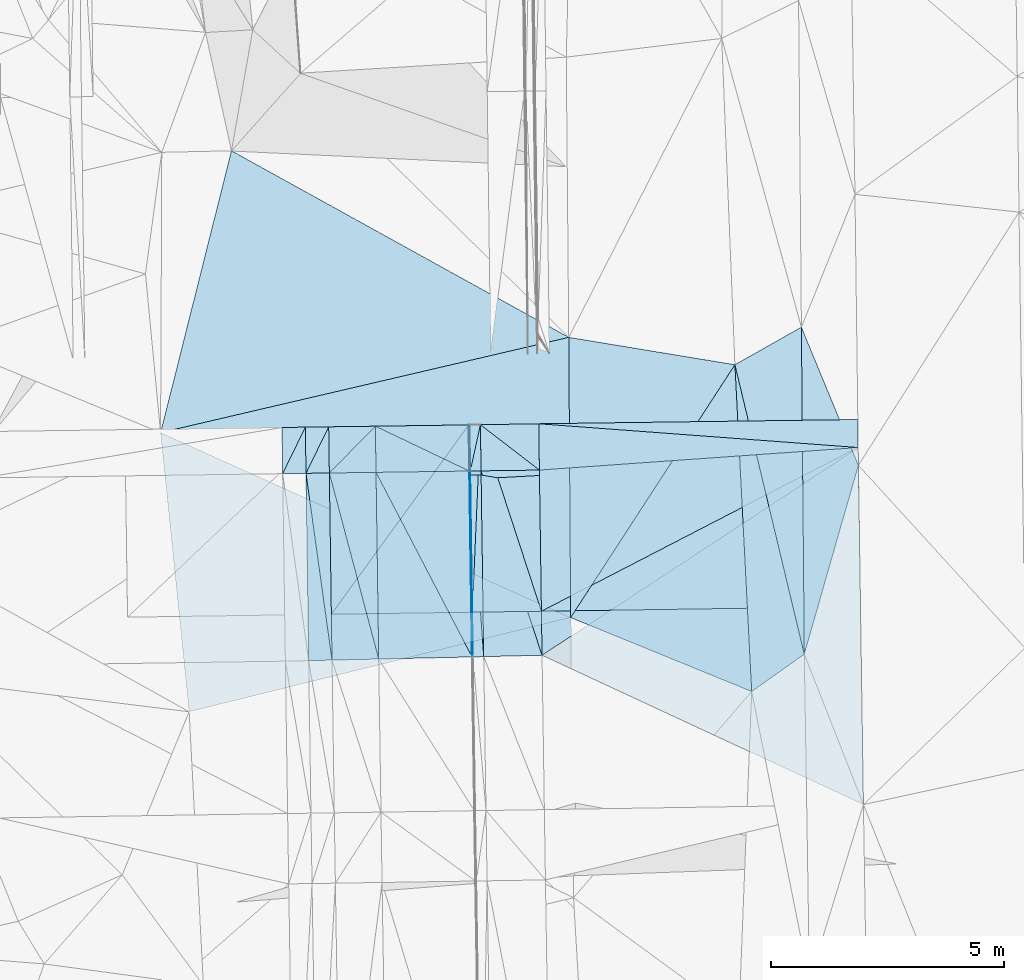
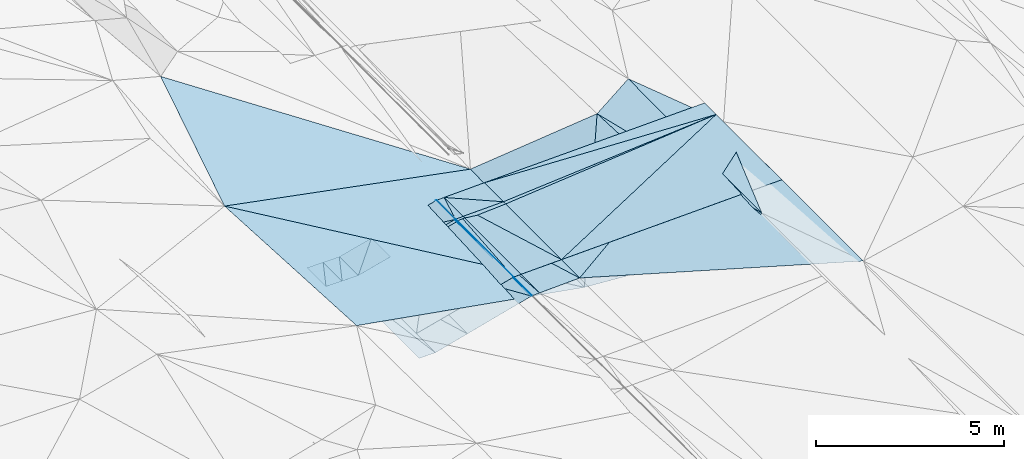
# One storey, part 8 of 275: 46 plates.
"""IFC2X3 building model written with IfcOpenShell, lengths in millimetres."""

from ifc_helpers import new_model, si_unit, frame, origin_with_axes, place, context, subcontext, project, spatial, polyline, outline, extrude, material, type_object, element, save


model = new_model("IFC2X3")

# Units and contexts
model_context = context("Model", 3, precision=1e-05, world=origin_with_axes())
body_context = subcontext(model_context, "Body", "Model", "MODEL_VIEW")
ifc_project = project(units=[si_unit("LENGTHUNIT", "METRE", prefix="MILLI"), si_unit("AREAUNIT", "SQUARE_METRE"), si_unit("VOLUMEUNIT", "CUBIC_METRE"), si_unit("MASSUNIT", "GRAM", prefix="KILO"), si_unit("TIMEUNIT", "SECOND"), si_unit("PLANEANGLEUNIT", "RADIAN"), si_unit("SOLIDANGLEUNIT", "STERADIAN"), si_unit("THERMODYNAMICTEMPERATUREUNIT", "DEGREE_CELSIUS"), si_unit("LUMINOUSINTENSITYUNIT", "LUMEN")], contexts=[model_context])

# Site, building, storey
site_placement = place(None, origin_with_axes())
site = spatial("IfcSite", under=ifc_project, at=site_placement, CompositionType="ELEMENT")
building_placement = place(site_placement, origin_with_axes())
building = spatial("IfcBuilding", under=site, at=building_placement, Name="Undefined", CompositionType="ELEMENT")
storey_placement = place(building_placement, origin_with_axes())
storey = spatial("IfcBuildingStorey", under=building, at=storey_placement, Name="Undefined", CompositionType="ELEMENT", Elevation=0.0)

# Plates
ifc_material = material()
plate_type_1 = type_object("IfcPlateType", PredefinedType="NOTDEFINED")
plate_1_placement = place(storey_placement, frame((-93513.8792285141, -4218.71586705667, 40889.5652154385), z_axis=(0.020856798243024, 0.0210911512834636, -0.999559981844305), x_axis=(-0.999682181351949, -0.013720854073878, -0.0211488640567715)))
element("IfcPlate", 1, at=plate_1_placement, inside=storey, type_object=plate_type_1, material=ifc_material, Name="00_PR", context=body_context, shape_type="SweptSolid", body=[
    extrude(outline(polyline([(0.0, 0.0), (1250.27990722656, -3.6216079024598e-09), (1250.25964355469, 4012.908203125), (0.0, 0.0)])), frame((-8.85201319254618e-08, 2.18876761149539e-07, -0.5000001331573), z_axis=(0.0, 0.0, 1.0), x_axis=(1.0, 0.0, 0.0)), (0.0, 0.0, 1.0), 1.0),
])
plate_2_placement = place(storey_placement, frame((-94806.8270014594, -1212.06963349907, 40926.3082572513), z_axis=(0.0213601280528179, 0.0242065290149965, -0.999478758595006), x_axis=(0.999666624616128, 0.0139865780369808, 0.0217028860618247)))
element("IfcPlate", 2, at=plate_2_placement, inside=storey, type_object=plate_type_1, material=ifc_material, Name="00_PR", context=body_context, shape_type="SweptSolid", body=[
    extrude(outline(polyline([(0.0, 0.0), (1250.29455566406, 7.65987806516932e-09), (1249.54223632813, 3968.11083984375), (0.0, 0.0)])), frame((-8.85201319254618e-08, 2.18876761149539e-07, -0.5000001331573), z_axis=(0.0, 0.0, 1.0), x_axis=(1.0, 0.0, 0.0)), (0.0, 0.0, 1.0), 1.0),
])
plate_type_2 = type_object("IfcPlateType", PredefinedType="NOTDEFINED")
plate_3_placement = place(storey_placement, frame((-95070.5289953847, -227.688733123045, 40934.0857272402), z_axis=(0.0496352265912636, 0.021474022861793, -0.998536534445969), x_axis=(0.998656775139546, 0.0138135640697415, 0.0499382710510996)))
element("IfcPlate", 3, at=plate_3_placement, inside=storey, type_object=plate_type_2, material=ifc_material, Name="00_PR", context=body_context, shape_type="SweptSolid", body=[
    extrude(outline(polyline([(0.0, 0.0), (20.0247211456299, -8.70841176947579e-11), (17.1715545654297, 4013.0234375), (0.0, 0.0)])), frame((-8.85201319254618e-08, 2.18876761149539e-07, -0.5000001331573), z_axis=(0.0, 0.0, 1.0), x_axis=(1.0, 0.0, 0.0)), (0.0, 0.0, 1.0), 1.0),
])
plate_4_placement = place(storey_placement, frame((-94993.7237407446, -4239.16661291406, 40851.6347403939), z_axis=(0.0501697240407511, 0.0214837039195709, -0.998509614002575), x_axis=(-0.998620028702754, -0.0144622870635318, -0.050486439036657)))
element("IfcPlate", 4, at=plate_4_placement, inside=storey, type_object=plate_type_2, material=ifc_material, Name="00_PR", context=body_context, shape_type="SweptSolid", body=[
    extrude(outline(polyline([(0.0, 0.0), (20.0252170562744, 7.18500814400613e-11), (14.5211954116821, 4013.03393554688), (0.0, 0.0)])), frame((-8.85201319254618e-08, 2.18876761149539e-07, -0.5000001331573), z_axis=(0.0, 0.0, 1.0), x_axis=(1.0, 0.0, 0.0)), (0.0, 0.0, 1.0), 1.0),
])
plate_5_placement = place(storey_placement, frame((-95056.7891255889, -1215.56620002992, 40913.8087657307), z_axis=(0.0495786226448783, 0.024871184922841, -0.998460507149467), x_axis=(0.998655085639117, 0.0139446040450681, 0.0499356380269003)))
element("IfcPlate", 5, at=plate_5_placement, inside=storey, type_object=plate_type_2, material=ifc_material, Name="00_PR", context=body_context, shape_type="SweptSolid", body=[
    extrude(outline(polyline([(0.0, 0.0), (20.0257778167725, 1.17097442853265e-10), (16.6394844055176, 3983.24291992188), (0.0, 0.0)])), frame((-8.85201319254618e-08, 2.18876761149539e-07, -0.5000001331573), z_axis=(0.0, 0.0, 1.0), x_axis=(1.0, 0.0, 0.0)), (0.0, 0.0, 1.0), 1.0),
])
plate_6_placement = place(storey_placement, frame((-94979.7657640739, -5196.95761697948, 40818.4587655052), z_axis=(0.0495682391287565, 0.024870996833914, -0.99846102737471), x_axis=(-0.998485170887657, -0.0226700710471939, -0.0501341340421996)))
element("IfcPlate", 6, at=plate_6_placement, inside=storey, type_object=plate_type_2, material=ifc_material, Name="00_PR", context=body_context, shape_type="SweptSolid", body=[
    extrude(outline(polyline([(0.0, 0.0), (20.0262756347656, -1.20962795335799e-10), (-18.1320266723633, 3983.23657226563), (0.0, 0.0)])), frame((-8.85201319254618e-08, 2.18876761149539e-07, -0.5000001331573), z_axis=(0.0, 0.0, 1.0), x_axis=(1.0, 0.0, 0.0)), (0.0, 0.0, 1.0), 1.0),
])
plate_type_3 = type_object("IfcPlateType", PredefinedType="NOTDEFINED")
plate_7_placement = place(storey_placement, frame((-92927.8955696093, 1648.04519571501, 40070.5341664942), z_axis=(-0.351449280136306, 0.0924008360437284, -0.931635920835007), x_axis=(-0.92063278624833, -0.21486555561597, 0.325987830899371)))
element("IfcPlate", 7, at=plate_7_placement, inside=storey, type_object=plate_type_3, material=ifc_material, Name="00", context=body_context, shape_type="SweptSolid", body=[
    extrude(outline(polyline([(0.0, 0.0), (9497.287109375, -4.51691448688507e-08), (6810.59228515625, 5616.0224609375), (0.0, 0.0)])), frame((-8.85201319254618e-08, 2.18876761149539e-07, -0.5000001331573), z_axis=(0.0, 0.0, 1.0), x_axis=(1.0, 0.0, 0.0)), (0.0, 0.0, 1.0), 1.0),
])
plate_type_4 = type_object("IfcPlateType", PredefinedType="NOTDEFINED")
plate_8_placement = place(storey_placement, frame((-98570.2324279572, -275.173630976212, 40184.0840997958), z_axis=(-0.000285244655797323, 0.020485111785023, -0.999790117389966), x_axis=(-0.438469244025639, -0.898560153204292, -0.0182858720619226)))
element("IfcPlate", 8, at=plate_8_placement, inside=storey, type_object=plate_type_4, material=ifc_material, Name="00_PR", context=body_context, shape_type="SweptSolid", body=[
    extrude(outline(polyline([(0.0, 0.0), (1108.83410644531, 3.47790773957968e-09), (225.425186157227, 446.299774169922), (0.0, 0.0)])), frame((-8.85201319254618e-08, 2.18876761149539e-07, -0.5000001331573), z_axis=(0.0, 0.0, 1.0), x_axis=(1.0, 0.0, 0.0)), (0.0, 0.0, 1.0), 1.0),
])
plate_9_placement = place(storey_placement, frame((-99056.4221080373, -1271.52782889279, 40163.8080998014), z_axis=(-0.000286633495761697, 0.0204857892090458, -0.999790103112509), x_axis=(0.438469244027319, 0.898560153203397, 0.0182858720656048)))
element("IfcPlate", 9, at=plate_9_placement, inside=storey, type_object=plate_type_4, material=ifc_material, Name="00_PR", context=body_context, shape_type="SweptSolid", body=[
    extrude(outline(polyline([(0.0, 0.0), (1108.83410644531, 3.47790773957968e-09), (225.498657226563, 446.262298583984), (0.0, 0.0)])), frame((-8.85201319254618e-08, 2.18876761149539e-07, -0.5000001331573), z_axis=(0.0, 0.0, 1.0), x_axis=(1.0, 0.0, 0.0)), (0.0, 0.0, 1.0), 1.0),
])
plate_10_placement = place(storey_placement, frame((-98070.2802241063, -268.260858650966, 40184.0840998927), z_axis=(-0.000283254981954454, 0.0204858370799492, -0.999790103094519), x_axis=(-0.43849960803537, -0.898545311216675, -0.01828708405833)))
element("IfcPlate", 10, at=plate_10_placement, inside=storey, type_object=plate_type_4, material=ifc_material, Name="00_PR", context=body_context, shape_type="SweptSolid", body=[
    extrude(outline(polyline([(0.0, 0.0), (1108.7607421875, 1.23691279441118e-09), (225.440277099609, 446.292144775391), (0.0, 0.0)])), frame((-8.85201319254618e-08, 2.18876761149539e-07, -0.5000001331573), z_axis=(0.0, 0.0, 1.0), x_axis=(1.0, 0.0, 0.0)), (0.0, 0.0, 1.0), 1.0),
])
plate_11_placement = place(storey_placement, frame((-98556.4713669561, -1264.53260535774, 40163.8080998936), z_axis=(-0.000286657384777683, 0.020487496770318, -0.999790068116117), x_axis=(0.438499608036022, 0.898545311216472, 0.0182870840526721)))
element("IfcPlate", 11, at=plate_11_placement, inside=storey, type_object=plate_type_4, material=ifc_material, Name="00_PR", context=body_context, shape_type="SweptSolid", body=[
    extrude(outline(polyline([(0.0, 0.0), (1108.7607421875, 1.23691279441118e-09), (225.513732910156, 446.254669189453), (0.0, 0.0)])), frame((-8.85201319254618e-08, 2.18876761149539e-07, -0.5000001331573), z_axis=(0.0, 0.0, 1.0), x_axis=(1.0, 0.0, 0.0)), (0.0, 0.0, 1.0), 1.0),
])
plate_12_placement = place(storey_placement, frame((-98556.4713920251, -1264.53076200892, 40163.8081412147), z_axis=(-0.000338241756777062, 0.0241742518381075, -0.999707702851479), x_axis=(0.999902128808213, 0.0139904540599465, 6.75791380713796e-11)))
element("IfcPlate", 12, at=plate_12_placement, inside=storey, type_object=plate_type_4, material=ifc_material, Name="00_PR", context=body_context, shape_type="SweptSolid", body=[
    extrude(outline(polyline([(0.0, 0.0), (499.999664306641, 2.92175172944553e-09), (501.330810546875, 4009.45239257813), (0.0, 0.0)])), frame((-8.85201319254618e-08, 2.18876761149539e-07, -0.5000001331573), z_axis=(0.0, 0.0, 1.0), x_axis=(1.0, 0.0, 0.0)), (0.0, 0.0, 1.0), 1.0),
])
plate_type_5 = type_object("IfcPlateType", PredefinedType="NOTDEFINED")
plate_13_placement = place(storey_placement, frame((-94820.5533522742, -224.232548711779, 40946.585727181), z_axis=(0.0496352265912636, 0.021474022861793, -0.998536534445969), x_axis=(-0.0430795449239569, -0.998792373883062, -0.0236208950334792)))
element("IfcPlate", 13, at=plate_13_placement, inside=storey, type_object=plate_type_5, material=ifc_material, Name="00_PR", context=body_context, shape_type="SweptSolid", body=[
    extrude(outline(polyline([(0.0, 0.0), (4019.78857421875, -8.00355337560177e-10), (13.3547115325928, 229.899566650391), (0.0, 0.0)])), frame((-8.85201319254618e-08, 2.18876761149539e-07, -0.5000001331573), z_axis=(0.0, 0.0, 1.0), x_axis=(1.0, 0.0, 0.0)), (0.0, 0.0, 1.0), 1.0),
])
plate_14_placement = place(storey_placement, frame((-94820.5533522742, -224.232548711779, 40946.585727181), z_axis=(0.0495764798683866, 0.0214765971361486, -0.998539397529868), x_axis=(0.0141557210746954, -0.999683485276561, -0.0207977120415579)))
element("IfcPlate", 14, at=plate_14_placement, inside=storey, type_object=plate_type_5, material=ifc_material, Name="00_PR", context=body_context, shape_type="SweptSolid", body=[
    extrude(outline(polyline([(0.0, 0.0), (4012.908203125, -8.73114913702011e-11), (4013.18676757813, 230.286849975586), (0.0, 0.0)])), frame((-8.85201319254618e-08, 2.18876761149539e-07, -0.5000001331573), z_axis=(0.0, 0.0, 1.0), x_axis=(1.0, 0.0, 0.0)), (0.0, 0.0, 1.0), 1.0),
])
plate_15_placement = place(storey_placement, frame((-94820.5655017546, -223.327290101327, 40946.582724586), z_axis=(0.0496043560582936, 0.0211722559886523, -0.99854451249626), x_axis=(-0.212871790901862, -0.976579275792028, -0.0312812840489783)))
element("IfcPlate", 15, at=plate_15_placement, inside=storey, type_object=plate_type_5, material=ifc_material, Name="00_PR", context=body_context, shape_type="SweptSolid", body=[
    extrude(outline(polyline([(0.0, 0.0), (1015.75115966797, -2.18278728425503e-10), (52.4217758178711, 224.241333007813), (0.0, 0.0)])), frame((-8.85201319254618e-08, 2.18876761149539e-07, -0.5000001331573), z_axis=(0.0, 0.0, 1.0), x_axis=(1.0, 0.0, 0.0)), (0.0, 0.0, 1.0), 1.0),
])
plate_16_placement = place(storey_placement, frame((-95036.7902768053, -1215.28694899913, 40914.8087666688), z_axis=(0.0495799421778808, 0.0248720159562137, -0.998460420926094), x_axis=(0.998654598065584, 0.0139723250467991, 0.04993764006492)))
element("IfcPlate", 16, at=plate_16_placement, inside=storey, type_object=plate_type_5, material=ifc_material, Name="00_PR", context=body_context, shape_type="SweptSolid", body=[
    extrude(outline(polyline([(0.0, 0.0), (230.287216186523, -1.21326593216509e-09), (226.79150390625, 3981.24755859375), (0.0, 0.0)])), frame((-8.85201319254618e-08, 2.18876761149539e-07, -0.5000001331573), z_axis=(0.0, 0.0, 1.0), x_axis=(1.0, 0.0, 0.0)), (0.0, 0.0, 1.0), 1.0),
])
plate_17_placement = place(storey_placement, frame((-94749.8173574329, -5191.74536326647, 40830.0037659832), z_axis=(0.0495659011723435, 0.0248710178439661, -0.998461142915626), x_axis=(-0.998486179408578, -0.0226327480537173, -0.0501309110788782)))
element("IfcPlate", 17, at=plate_17_placement, inside=storey, type_object=plate_type_5, material=ifc_material, Name="00_PR", context=body_context, shape_type="SweptSolid", body=[
    extrude(outline(polyline([(0.0, 0.0), (230.297027587891, 6.19365891907364e-10), (192.288970947266, 3983.06323242188), (0.0, 0.0)])), frame((-8.85201319254618e-08, 2.18876761149539e-07, -0.5000001331573), z_axis=(0.0, 0.0, 1.0), x_axis=(1.0, 0.0, 0.0)), (0.0, 0.0, 1.0), 1.0),
])
plate_type_6 = type_object("IfcPlateType", PredefinedType="NOTDEFINED")
plate_18_placement = place(storey_placement, frame((-95056.6928214176, -1215.5670102283, 40913.823020367), z_axis=(0.242186058975934, 0.0232509066176625, -0.969951188554951), x_axis=(-0.970047548903161, -0.0135718400412121, -0.242535684023742)))
element("IfcPlate", 18, at=plate_18_placement, inside=storey, type_object=plate_type_6, material=ifc_material, Name="00_PR", context=body_context, shape_type="SweptSolid", body=[
    extrude(outline(polyline([(0.0, 0.0), (2061.55224609375, 3.28782334690914e-10), (2056.556640625, 989.402954101563), (0.0, 0.0)])), frame((-8.85201319254618e-08, 2.18876761149539e-07, -0.5000001331573), z_axis=(0.0, 0.0, 1.0), x_axis=(1.0, 0.0, 0.0)), (0.0, 0.0, 1.0), 1.0),
])
plate_type_7 = type_object("IfcPlateType", PredefinedType="NOTDEFINED")
plate_19_placement = place(storey_placement, frame((-97999.1119917879, -5265.40507719327, 40066.8731411073), z_axis=(-0.00035402371759246, 0.0241721850526879, -0.999707747362691), x_axis=(-0.999743131890957, -0.0226634640592878, -0.000193994058953439)))
element("IfcPlate", 19, at=plate_19_placement, inside=storey, type_object=plate_type_7, material=ifc_material, Name="00_PR", context=body_context, shape_type="SweptSolid", body=[
    extrude(outline(polyline([(0.0, 0.0), (500.016204833984, -1.46019374369644e-09), (466.523773193359, 4013.6513671875), (0.0, 0.0)])), frame((-8.85201319254618e-08, 2.18876761149539e-07, -0.5000001331573), z_axis=(0.0, 0.0, 1.0), x_axis=(1.0, 0.0, 0.0)), (0.0, 0.0, 1.0), 1.0),
])
plate_type_8 = type_object("IfcPlateType", PredefinedType="NOTDEFINED")
plate_20_placement = place(storey_placement, frame((-87882.3094481917, -5139.54234992222, 40990.5050329324), z_axis=(0.13804967795513, 0.0319725782794983, -0.989909107269272), x_axis=(-0.808764304319142, -0.573288343177908, -0.13130413411429)))
element("IfcPlate", 20, at=plate_20_placement, inside=storey, type_object=plate_type_8, material=ifc_material, Name="00", context=body_context, shape_type="SweptSolid", body=[
    extrude(outline(polyline([(0.0, 0.0), (1393.71081542969, 5.36238076165318e-09), (-2352.12768554688, 5927.56103515625), (0.0, 0.0)])), frame((-8.85201319254618e-08, 2.18876761149539e-07, -0.5000001331573), z_axis=(0.0, 0.0, 1.0), x_axis=(1.0, 0.0, 0.0)), (0.0, 0.0, 1.0), 1.0),
])
plate_type_9 = type_object("IfcPlateType", PredefinedType="NOTDEFINED")
plate_21_placement = place(storey_placement, frame((-95070.4327222343, -227.687672295305, 40934.1000235878), z_axis=(0.242182843880682, 0.023595710229853, -0.969943664646877), x_axis=(-0.579382769058458, -0.798367860202229, -0.164086461093742)))
element("IfcPlate", 21, at=plate_21_placement, inside=storey, type_object=plate_type_9, material=ifc_material, Name="00_PR", context=body_context, shape_type="SweptSolid", body=[
    extrude(outline(polyline([(0.0, 0.0), (5079.33447265625, -1.94413587450981e-08), (1894.16064453125, 2444.31079101563), (0.0, 0.0)])), frame((-8.85201319254618e-08, 2.18876761149539e-07, -0.5000001331573), z_axis=(0.0, 0.0, 1.0), x_axis=(1.0, 0.0, 0.0)), (0.0, 0.0, 1.0), 1.0),
])
plate_type_10 = type_object("IfcPlateType", PredefinedType="NOTDEFINED")
plate_22_placement = place(storey_placement, frame((-95070.4327222343, -227.687672295305, 40934.1000235878), z_axis=(0.242166686192209, 0.023608203021497, -0.969947394887362), x_axis=(0.0141557210746954, -0.999683485276561, -0.0207977120415579)))
element("IfcPlate", 22, at=plate_22_placement, inside=storey, type_object=plate_type_10, material=ifc_material, Name="00_PR", context=body_context, shape_type="SweptSolid", body=[
    extrude(outline(polyline([(0.0, 0.0), (4013.03759765625, 1.30967237055302e-10), (4029.56909179688, 3092.28247070313), (0.0, 0.0)])), frame((-8.85201319254618e-08, 2.18876761149539e-07, -0.5000001331573), z_axis=(0.0, 0.0, 1.0), x_axis=(1.0, 0.0, 0.0)), (0.0, 0.0, 1.0), 1.0),
])
plate_type_11 = type_object("IfcPlateType", PredefinedType="NOTDEFINED")
plate_23_placement = place(storey_placement, frame((-94820.5674085685, -224.232631660958, 40946.5852248062), z_axis=(0.0215214443836006, 0.0213083054264728, -0.999541286566741), x_axis=(0.999615621800982, 0.0170181860656543, 0.0218858400448864)))
element("IfcPlate", 23, at=plate_23_placement, inside=storey, type_object=plate_type_11, material=ifc_material, Name="00_PR", context=body_context, shape_type="SweptSolid", body=[
    extrude(outline(polyline([(0.0, 0.0), (1250.30615234375, -8.54060999699868e-09), (1236.95947265625, 4017.02783203125), (0.0, 0.0)])), frame((-8.85201319254618e-08, 2.18876761149539e-07, -0.5000001331573), z_axis=(0.0, 0.0, 1.0), x_axis=(1.0, 0.0, 0.0)), (0.0, 0.0, 1.0), 1.0),
])
plate_24_placement = place(storey_placement, frame((-87882.3671847648, -5139.54810316311, 40990.5002121622), z_axis=(0.0225807150640095, 0.020459013950742, -0.999535662222895), x_axis=(-0.00887475666106982, 0.999755294456456, 0.0202630180499455)))
element("IfcPlate", 24, at=plate_24_placement, inside=storey, type_object=plate_type_11, material=ifc_material, Name="00", context=body_context, shape_type="SweptSolid", body=[
    extrude(outline(polyline([(0.0, 0.0), (7007.84033203125, 2.09547579288483e-09), (4037.05395507813, 1195.1220703125), (0.0, 0.0)])), frame((-8.85201319254618e-08, 2.18876761149539e-07, -0.5000001331573), z_axis=(0.0, 0.0, 1.0), x_axis=(1.0, 0.0, 0.0)), (0.0, 0.0, 1.0), 1.0),
])
plate_type_12 = type_object("IfcPlateType", PredefinedType="NOTDEFINED")
plate_25_placement = place(storey_placement, frame((-86728.2827109371, -711.746785404917, 41110.3362403316), z_axis=(0.0216030203098031, 0.0225975031308767, -0.999511211725884), x_axis=(-0.997049886137921, 0.0741388059410694, -0.019873651048348)))
element("IfcPlate", 25, at=plate_25_placement, inside=storey, type_object=plate_type_12, material=ifc_material, Name="00_PR", context=body_context, shape_type="SweptSolid", body=[
    extrude(outline(polyline([(0.0, 0.0), (6862.705078125, -3.5979610402137e-09), (51.8262901306152, 597.907470703125), (0.0, 0.0)])), frame((-8.85201319254618e-08, 2.18876761149539e-07, -0.5000001331573), z_axis=(0.0, 0.0, 1.0), x_axis=(1.0, 0.0, 0.0)), (0.0, 0.0, 1.0), 1.0),
])
plate_type_13 = type_object("IfcPlateType", PredefinedType="NOTDEFINED")
plate_26_placement = place(storey_placement, frame((-86728.283099153, -711.746771819483, 41110.3362322811), z_axis=(0.0208268434803722, 0.0226246820961738, -0.999527071344589), x_axis=(0.0145651370712101, -0.999644688015907, -0.0223238550361824)))
element("IfcPlate", 26, at=plate_26_placement, inside=storey, type_object=plate_type_13, material=ifc_material, Name="00_PR", context=body_context, shape_type="SweptSolid", body=[
    extrude(outline(polyline([(0.0, 0.0), (3408.41674804688, -3.63797880709171e-10), (3411.81762695313, 6837.498046875), (0.0, 0.0)])), frame((-8.85201319254618e-08, 2.18876761149539e-07, -0.5000001331573), z_axis=(0.0, 0.0, 1.0), x_axis=(1.0, 0.0, 0.0)), (0.0, 0.0, 1.0), 1.0),
])
plate_type_14 = type_object("IfcPlateType", PredefinedType="NOTDEFINED")
plate_27_placement = place(storey_placement, frame((-93513.8789029444, -4218.71575872007, 40889.5652245097), z_axis=(0.0215077493631325, 0.0213081184502283, -0.999541585330717), x_axis=(-0.014155402073056, 0.999679125134027, 0.0210064600400868)))
element("IfcPlate", 27, at=plate_27_placement, inside=storey, type_object=plate_type_14, material=ifc_material, Name="00_PR", context=body_context, shape_type="SweptSolid", body=[
    extrude(outline(polyline([(0.0, 0.0), (4017.05004882813, 1.28056854009628e-09), (3414.427734375, 6836.1953125), (0.0, 0.0)])), frame((-8.85201319254618e-08, 2.18876761149539e-07, -0.5000001331573), z_axis=(0.0, 0.0, 1.0), x_axis=(1.0, 0.0, 0.0)), (0.0, 0.0, 1.0), 1.0),
])
plate_type_15 = type_object("IfcPlateType", PredefinedType="NOTDEFINED")
plate_28_placement = place(storey_placement, frame((-97070.2545839961, -254.433930396027, 40434.0980201094), z_axis=(0.242188423694539, 0.0232484387251282, -0.969950657263141), x_axis=(-0.688460636905486, -0.700299069991582, -0.188688007039712)))
element("IfcPlate", 28, at=plate_28_placement, inside=storey, type_object=plate_type_15, material=ifc_material, Name="00_PR", context=body_context, shape_type="SweptSolid", body=[
    extrude(outline(polyline([(0.0, 0.0), (1432.39099121094, 3.688910510391e-09), (745.248657226563, 712.1123046875), (0.0, 0.0)])), frame((-8.85201319254618e-08, 2.18876761149539e-07, -0.5000001331573), z_axis=(0.0, 0.0, 1.0), x_axis=(1.0, 0.0, 0.0)), (0.0, 0.0, 1.0), 1.0),
])
plate_29_placement = place(storey_placement, frame((-98056.399393265, -1257.53600238642, 40163.8230197611), z_axis=(0.242186058975934, 0.0232509066176625, -0.969951188554951), x_axis=(0.688460636906628, 0.700299069990728, 0.188688007038716)))
element("IfcPlate", 29, at=plate_29_placement, inside=storey, type_object=plate_type_15, material=ifc_material, Name="00_PR", context=body_context, shape_type="SweptSolid", body=[
    extrude(outline(polyline([(0.0, 0.0), (1432.39099121094, 3.688910510391e-09), (745.362854003906, 711.994079589844), (0.0, 0.0)])), frame((-8.85201319254618e-08, 2.18876761149539e-07, -0.5000001331573), z_axis=(0.0, 0.0, 1.0), x_axis=(1.0, 0.0, 0.0)), (0.0, 0.0, 1.0), 1.0),
])
plate_type_16 = type_object("IfcPlateType", PredefinedType="NOTDEFINED")
plate_30_placement = place(storey_placement, frame((-98056.3994292089, -1257.53416304287, 40163.823058705), z_axis=(0.242115221726422, 0.0269294553576331, -0.969873715409644), x_axis=(0.970047596052884, 0.0135722220519551, 0.242535474066359)))
element("IfcPlate", 30, at=plate_30_placement, inside=storey, type_object=plate_type_16, material=ifc_material, Name="00_PR", context=body_context, shape_type="SweptSolid", body=[
    extrude(outline(polyline([(0.0, 0.0), (1030.77709960938, 6.45741238258779e-10), (1008.60101318359, 4000.712890625), (0.0, 0.0)])), frame((-8.85201319254618e-08, 2.18876761149539e-07, -0.5000001331573), z_axis=(0.0, 0.0, 1.0), x_axis=(1.0, 0.0, 0.0)), (0.0, 0.0, 1.0), 1.0),
])
plate_type_17 = type_object("IfcPlateType", PredefinedType="NOTDEFINED")
plate_31_placement = place(storey_placement, frame((-96999.2156247979, -5242.73858425949, 40317.0810569239), z_axis=(0.242100716851496, 0.0269254644314393, -0.969877447033976), x_axis=(-0.969851070316829, -0.0219867310558067, -0.242704522130883)))
element("IfcPlate", 31, at=plate_31_placement, inside=storey, type_object=plate_type_17, material=ifc_material, Name="00_PR", context=body_context, shape_type="SweptSolid", body=[
    extrude(outline(polyline([(0.0, 0.0), (1030.85424804688, -1.11162989924196e-09), (974.885620117188, 4009.06201171875), (0.0, 0.0)])), frame((-8.85201319254618e-08, 2.18876761149539e-07, -0.5000001331573), z_axis=(0.0, 0.0, 1.0), x_axis=(1.0, 0.0, 0.0)), (0.0, 0.0, 1.0), 1.0),
])
plate_type_18 = type_object("IfcPlateType", PredefinedType="NOTDEFINED")
plate_32_placement = place(storey_placement, frame((-94999.6654302837, -5197.4105813226, 40817.4690592262), z_axis=(0.242115294393012, 0.0269368579230719, -0.969873491701994), x_axis=(-0.459616538832816, 0.883525285577623, -0.0901981539518536)))
element("IfcPlate", 32, at=plate_32_placement, inside=storey, type_object=plate_type_18, material=ifc_material, Name="00_PR", context=body_context, shape_type="SweptSolid", body=[
    extrude(outline(polyline([(0.0, 0.0), (4475.1025390625, 7.20319803804159e-09), (3535.58081054688, 1835.01953125), (0.0, 0.0)])), frame((-8.85201319254618e-08, 2.18876761149539e-07, -0.5000001331573), z_axis=(0.0, 0.0, 1.0), x_axis=(1.0, 0.0, 0.0)), (0.0, 0.0, 1.0), 1.0),
])
plate_type_19 = type_object("IfcPlateType", PredefinedType="NOTDEFINED")
plate_33_placement = place(storey_placement, frame((-96999.2156247979, -5242.73858425949, 40317.0810569239), z_axis=(0.24210156264426, 0.0269293430330467, -0.969877128222444), x_axis=(-0.0143174810509686, 0.999605070879271, 0.0241808190267303)))
element("IfcPlate", 33, at=plate_33_placement, inside=storey, type_object=plate_type_19, material=ifc_material, Name="00_PR", context=body_context, shape_type="SweptSolid", body=[
    extrude(outline(polyline([(0.0, 0.0), (4000.7744140625, -1.48429535329342e-09), (28.781364440918, 2061.50805664063), (0.0, 0.0)])), frame((-8.85201319254618e-08, 2.18876761149539e-07, -0.5000001331573), z_axis=(0.0, 0.0, 1.0), x_axis=(1.0, 0.0, 0.0)), (0.0, 0.0, 1.0), 1.0),
])
plate_type_20 = type_object("IfcPlateType", PredefinedType="NOTDEFINED")
plate_34_placement = place(storey_placement, frame((-95056.6928214176, -1215.5670102283, 40913.823020367), z_axis=(0.242188731516622, 0.0232564241061423, -0.969950388970573), x_axis=(-0.882297668238419, 0.421146990066632, -0.210204751085374)))
element("IfcPlate", 34, at=plate_34_placement, inside=storey, type_object=plate_type_20, material=ifc_material, Name="00_PR", context=body_context, shape_type="SweptSolid", body=[
    extrude(outline(polyline([(0.0, 0.0), (2282.1796875, 1.35405571199954e-08), (424.295989990234, 893.4580078125), (0.0, 0.0)])), frame((-8.85201319254618e-08, 2.18876761149539e-07, -0.5000001331573), z_axis=(0.0, 0.0, 1.0), x_axis=(1.0, 0.0, 0.0)), (0.0, 0.0, 1.0), 1.0),
])
plate_type_21 = type_object("IfcPlateType", PredefinedType="NOTDEFINED")
plate_35_placement = place(storey_placement, frame((-95036.7902497929, -1215.28880206687, 40914.8087252041), z_axis=(0.0496359366282971, 0.0211653265927758, -0.998543090079368), x_axis=(0.212871790902101, 0.976579275791875, 0.0312812840521059)))
element("IfcPlate", 35, at=plate_35_placement, inside=storey, type_object=plate_type_21, material=ifc_material, Name="00_PR", context=body_context, shape_type="SweptSolid", body=[
    extrude(outline(polyline([(0.0, 0.0), (1015.75115966797, -2.18278728425503e-10), (52.4577217102051, 224.232894897461), (0.0, 0.0)])), frame((-8.85201319254618e-08, 2.18876761149539e-07, -0.5000001331573), z_axis=(0.0, 0.0, 1.0), x_axis=(1.0, 0.0, 0.0)), (0.0, 0.0, 1.0), 1.0),
])
plate_type_22 = type_object("IfcPlateType", PredefinedType="NOTDEFINED")
plate_36_placement = place(storey_placement, frame((-94820.5795288673, -223.327388490641, 40946.5822226552), z_axis=(0.0215494340449189, 0.0209755318485989, -0.999547722200402), x_axis=(0.999627528648401, 0.0162940710388579, 0.0218930860609029)))
element("IfcPlate", 36, at=plate_36_placement, inside=storey, type_object=plate_type_22, material=ifc_material, Name="00_PR", context=body_context, shape_type="SweptSolid", body=[
    extrude(outline(polyline([(0.0, 0.0), (1250.30334472656, 3.62661012331955e-09), (1247.48413085938, 991.933044433594), (0.0, 0.0)])), frame((-8.85201319254618e-08, 2.18876761149539e-07, -0.5000001331573), z_axis=(0.0, 0.0, 1.0), x_axis=(1.0, 0.0, 0.0)), (0.0, 0.0, 1.0), 1.0),
])
plate_type_23 = type_object("IfcPlateType", PredefinedType="NOTDEFINED")
plate_37_placement = place(storey_placement, frame((-93556.9492638893, -1194.58399759763, 40953.4432193353), z_axis=(0.0214095261967044, 0.0207934600867687, -0.99955453288235), x_axis=(-0.999666624616105, -0.0139865780384297, -0.0217028860619808)))
element("IfcPlate", 37, at=plate_37_placement, inside=storey, type_object=plate_type_23, material=ifc_material, Name="00_PR", context=body_context, shape_type="SweptSolid", body=[
    extrude(outline(polyline([(0.0, 0.0), (1250.29455566406, 7.65987806516932e-09), (1249.7734375, 989.047180175781), (0.0, 0.0)])), frame((-8.85201319254618e-08, 2.18876761149539e-07, -0.5000001331573), z_axis=(0.0, 0.0, 1.0), x_axis=(1.0, 0.0, 0.0)), (0.0, 0.0, 1.0), 1.0),
])
plate_type_24 = type_object("IfcPlateType", PredefinedType="NOTDEFINED")
plate_38_placement = place(storey_placement, frame((-93500.1448526133, -5161.15252680679, 40858.5902707204), z_axis=(0.0222629116012459, 0.0245047817022658, -0.999451788952704), x_axis=(-0.999439182508093, -0.0244668330313916, -0.0228625140561537)))
element("IfcPlate", 38, at=plate_38_placement, inside=storey, type_object=plate_type_24, material=ifc_material, Name="00_PR", context=body_context, shape_type="SweptSolid", body=[
    extrude(outline(polyline([(0.0, 0.0), (1250.38745117188, -8.2577571447473e-09), (1207.77917480469, 3981.02124023438), (0.0, 0.0)])), frame((-8.85201319254618e-08, 2.18876761149539e-07, -0.5000001331573), z_axis=(0.0, 0.0, 1.0), x_axis=(1.0, 0.0, 0.0)), (0.0, 0.0, 1.0), 1.0),
])
plate_type_25 = type_object("IfcPlateType", PredefinedType="NOTDEFINED")
plate_39_placement = place(storey_placement, frame((-86728.2814724047, -711.803213271533, 41110.336249571), z_axis=(0.0222737099119042, 0.0226514914944086, -0.999495268512983), x_axis=(0.0146941350413663, -0.999642721535828, -0.0223273750321998)))
element("IfcPlate", 39, at=plate_39_placement, inside=storey, type_object=plate_type_25, material=ifc_material, Name="00_PR", context=body_context, shape_type="SweptSolid", body=[
    extrude(outline(polyline([(0.0, 0.0), (7651.41455078125, 5.82076609134674e-11), (4353.87451171875, 6838.27490234375), (0.0, 0.0)])), frame((-8.85201319254618e-08, 2.18876761149539e-07, -0.5000001331573), z_axis=(0.0, 0.0, 1.0), x_axis=(1.0, 0.0, 0.0)), (0.0, 0.0, 1.0), 1.0),
])
plate_type_26 = type_object("IfcPlateType", PredefinedType="NOTDEFINED")
plate_40_placement = place(storey_placement, frame((-93556.949223756, -1194.58390697896, 40953.4432220927), z_axis=(0.0214823966583579, 0.0209746294853072, -0.999549184158422), x_axis=(-0.0139047620396107, 0.999689475624955, 0.020678731037555)))
element("IfcPlate", 40, at=plate_40_placement, inside=storey, type_object=plate_type_26, material=ifc_material, Name="00_PR", context=body_context, shape_type="SweptSolid", body=[
    extrude(outline(polyline([(0.0, 0.0), (991.937072753906, 4.36557456851006e-11), (390.923278808594, 6836.341796875), (0.0, 0.0)])), frame((-8.85201319254618e-08, 2.18876761149539e-07, -0.5000001331573), z_axis=(0.0, 0.0, 1.0), x_axis=(1.0, 0.0, 0.0)), (0.0, 0.0, 1.0), 1.0),
])
plate_type_27 = type_object("IfcPlateType", PredefinedType="NOTDEFINED")
plate_41_placement = place(storey_placement, frame((-93500.1453526855, -5161.15267655409, 40858.590256044), z_axis=(0.0212524458781238, 0.0242050426276806, -0.99948109009405), x_axis=(-0.0143151200444425, 0.999611767048044, 0.02390381804652)))
element("IfcPlate", 41, at=plate_41_placement, inside=storey, type_object=plate_type_27, material=ifc_material, Name="00_PR", context=body_context, shape_type="SweptSolid", body=[
    extrude(outline(polyline([(0.0, 0.0), (3968.11083984375, -6.11180439591408e-10), (4356.70068359375, 6836.474609375), (0.0, 0.0)])), frame((-8.85201319254618e-08, 2.18876761149539e-07, -0.5000001331573), z_axis=(0.0, 0.0, 1.0), x_axis=(1.0, 0.0, 0.0)), (0.0, 0.0, 1.0), 1.0),
])
plate_type_28 = type_object("IfcPlateType", PredefinedType="NOTDEFINED")
plate_42_placement = place(storey_placement, frame((-89009.4350712293, -5938.53786237422, 40807.5167472748), z_axis=(0.254022877849429, 0.0373356940038468, -0.966477326936512), x_axis=(-0.902416018482904, 0.368703313592758, -0.222942136284695)))
element("IfcPlate", 42, at=plate_42_placement, inside=storey, type_object=plate_type_28, material=ifc_material, Name="00", context=body_context, shape_type="SweptSolid", body=[
    extrude(outline(polyline([(0.0, 0.0), (4297.0791015625, -3.03407432511449e-09), (2866.10864257813, 6399.43017578125), (0.0, 0.0)])), frame((-8.85201319254618e-08, 2.18876761149539e-07, -0.5000001331573), z_axis=(0.0, 0.0, 1.0), x_axis=(1.0, 0.0, 0.0)), (0.0, 0.0, 1.0), 1.0),
])
plate_type_29 = type_object("IfcPlateType", PredefinedType="NOTDEFINED")
plate_43_placement = place(storey_placement, frame((-92887.1880726884, -4354.19057594402, 39849.5167547872), z_axis=(0.254080573909414, 0.0372953637975244, -0.966463717788243), x_axis=(-0.00672693353533969, 0.999300229499478, 0.0367940170068696)))
element("IfcPlate", 43, at=plate_43_placement, inside=storey, type_object=plate_type_29, material=ifc_material, Name="00", context=body_context, shape_type="SweptSolid", body=[
    extrude(outline(polyline([(0.0, 0.0), (6006.4111328125, 2.31375452131033e-09), (5430.43408203125, 3675.69970703125), (0.0, 0.0)])), frame((-8.85201319254618e-08, 2.18876761149539e-07, -0.5000001331573), z_axis=(0.0, 0.0, 1.0), x_axis=(1.0, 0.0, 0.0)), (0.0, 0.0, 1.0), 1.0),
])
plate_type_30 = type_object("IfcPlateType", PredefinedType="NOTDEFINED")
plate_44_placement = place(storey_placement, frame((-89368.8107001579, 1061.96933021796, 40983.5022285865), z_axis=(0.092283104584877, 0.0209961938574424, -0.995511420553113), x_axis=(0.867084025628728, 0.48983381742732, 0.0907090061904411)))
element("IfcPlate", 44, at=plate_44_placement, inside=storey, type_object=plate_type_30, material=ifc_material, Name="00", context=body_context, shape_type="SweptSolid", body=[
    extrude(outline(polyline([(0.0, 0.0), (1642.615234375, -2.96131474897265e-09), (-1748.17626953125, 6132.8916015625), (0.0, 0.0)])), frame((-8.85201319254618e-08, 2.18876761149539e-07, -0.5000001331573), z_axis=(0.0, 0.0, 1.0), x_axis=(1.0, 0.0, 0.0)), (0.0, 0.0, 1.0), 1.0),
])
plate_type_31 = type_object("IfcPlateType", PredefinedType="NOTDEFINED")
plate_45_placement = place(storey_placement, frame((-101059.514273336, -6371.78558485193, 42690.5296617022), z_axis=(-0.336987385100314, 0.040398137084833, -0.940642064126056), x_axis=(-0.101487209556557, 0.991699252884948, 0.0789489589789515)))
element("IfcPlate", 45, at=plate_45_placement, inside=storey, type_object=plate_type_31, material=ifc_material, Name="00", context=body_context, shape_type="SweptSolid", body=[
    extrude(outline(polyline([(0.0, 0.0), (6029.2119140625, -1.54250301420689e-09), (947.198425292969, 8833.2822265625), (0.0, 0.0)])), frame((-8.85201319254618e-08, 2.18876761149539e-07, -0.5000001331573), z_axis=(0.0, 0.0, 1.0), x_axis=(1.0, 0.0, 0.0)), (0.0, 0.0, 1.0), 1.0),
])
plate_type_32 = type_object("IfcPlateType", PredefinedType="NOTDEFINED")
plate_46_placement = place(storey_placement, frame((-92927.8899969212, 1648.01515222455, 40070.5301040309), z_axis=(-0.340301961024573, 0.0323110006164131, -0.93976091351045), x_axis=(0.00672693355639921, -0.999300229500191, -0.036794016983664)))
element("IfcPlate", 46, at=plate_46_placement, inside=storey, type_object=plate_type_32, material=ifc_material, Name="00", context=body_context, shape_type="SweptSolid", body=[
    extrude(outline(polyline([(0.0, 0.0), (6006.4111328125, 2.31375452131033e-09), (1866.48059082031, 9312.0732421875), (0.0, 0.0)])), frame((-8.85201319254618e-08, 2.18876761149539e-07, -0.5000001331573), z_axis=(0.0, 0.0, 1.0), x_axis=(1.0, 0.0, 0.0)), (0.0, 0.0, 1.0), 1.0),
])

save(model, "model.ifc")
